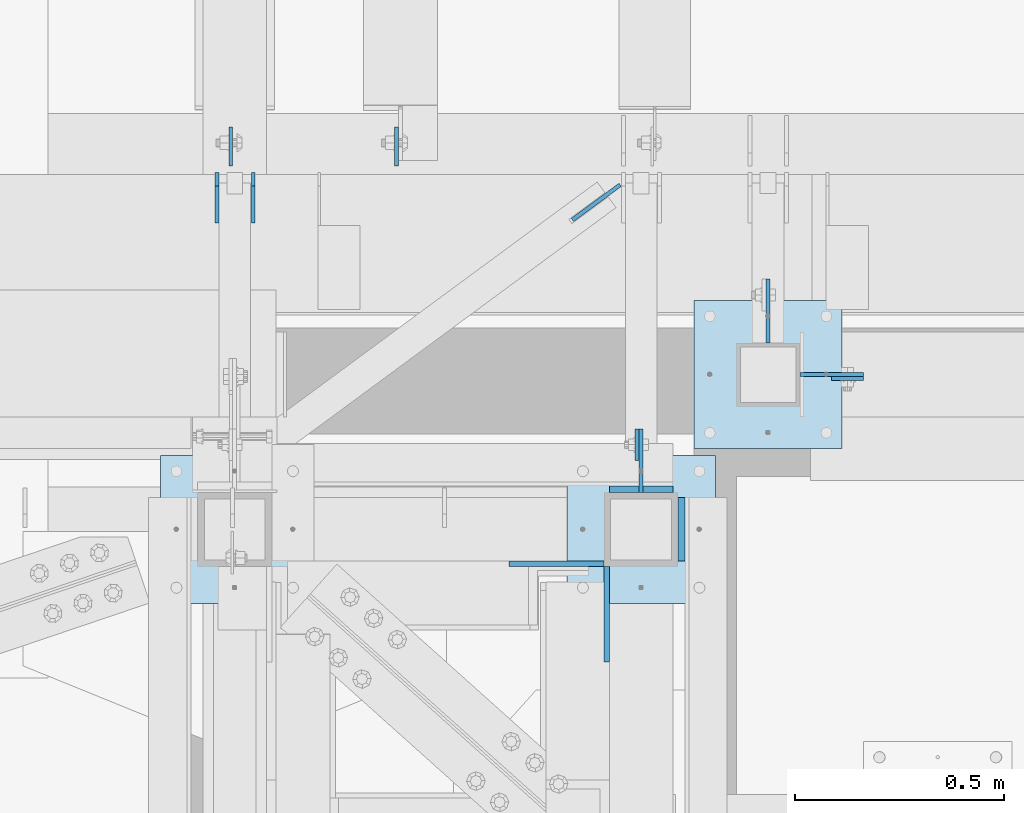
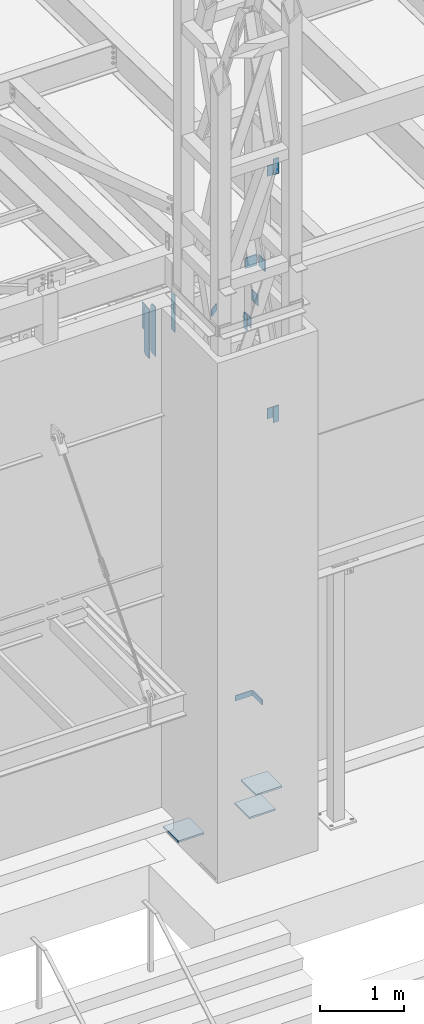
# One storey, part 1481 of 1763: 19 plates, 6 elements without a shape of their own.
"""IFC2X3 building model written with IfcOpenShell, lengths in millimetres."""

from ifc_helpers import new_model, si_unit, frame, origin_with_axes, place, context, subcontext, project, spatial, faceted_brep, material, type_object, element, aggregate, save


model = new_model("IFC2X3")

# Units and contexts
model_context = context("Model", 3, precision=1e-05, world=origin_with_axes())
body_context = subcontext(model_context, "Body", "Model", "MODEL_VIEW")
ifc_project = project(units=[si_unit("LENGTHUNIT", "METRE", prefix="MILLI"), si_unit("AREAUNIT", "SQUARE_METRE"), si_unit("VOLUMEUNIT", "CUBIC_METRE"), si_unit("MASSUNIT", "GRAM", prefix="KILO"), si_unit("TIMEUNIT", "SECOND"), si_unit("PLANEANGLEUNIT", "RADIAN"), si_unit("SOLIDANGLEUNIT", "STERADIAN"), si_unit("THERMODYNAMICTEMPERATUREUNIT", "DEGREE_CELSIUS"), si_unit("LUMINOUSINTENSITYUNIT", "LUMEN")], contexts=[model_context])

# Site, building, storey
site_placement = place(None, origin_with_axes())
site = spatial("IfcSite", under=ifc_project, at=site_placement, CompositionType="ELEMENT")
building_placement = place(site_placement, origin_with_axes())
building = spatial("IfcBuilding", under=site, at=building_placement, Name="Undefined", CompositionType="ELEMENT")
storey_placement = place(building_placement, origin_with_axes())
storey = spatial("IfcBuildingStorey", under=building, at=storey_placement, Name="Undefined", CompositionType="ELEMENT", Elevation=0.0)

# Assembly, plates
assembly_1_placement = place(storey_placement, origin_with_axes())
assembly_1 = element("IfcElementAssembly", 1, at=assembly_1_placement, inside=storey, Name="FRAME", AssemblyPlace="NOTDEFINED", PredefinedType="RIGID_FRAME")
ifc_material = material(Name="STEEL/A36")
plate_type_1 = type_object("IfcPlateType", PredefinedType="NOTDEFINED")
plate_1_placement = place(assembly_1_placement, frame((-47078.327008358, -14662.1506485031, 6845.29999694824), z_axis=(0.99999999999718, 2.37500000002911e-06, 0.0), x_axis=(0.0, 0.0, -1.0)))
plate_1 = element("IfcPlate", 2, at=plate_1_placement, type_object=plate_type_1, material=ifc_material, Name="PLATE", context=body_context, shape_type="Brep", body=[
    faceted_brep([(0.0, -6.34999999999491, 1.45519152283669e-11), (0.0, -6.35000000001855, 228.600006104178), (0.0, 6.34999999996944, 228.600006104134), (0.0, 6.34999999999491, -2.91038304567337e-11), (76.1999969482422, -6.35000000001855, 228.600006104178), (76.1999969482422, 6.34999999996944, 228.600006104134), (76.1999969482422, -6.34999999999491, 1.45519152283669e-11), (76.1999969482422, 6.34999999999491, -2.91038304567337e-11)], [[[0, 1, 2, 3]], [[1, 4, 5, 2]], [[4, 6, 7, 5]], [[6, 0, 3, 7]], [[5, 7, 3, 2]], [[6, 4, 1, 0]]]),
])
plate_2_placement = place(assembly_1_placement, frame((-46843.3772043448, -14897.1022094127, 6845.29999694824), z_axis=(0.0, 1.0, 0.0), x_axis=(0.0, 0.0, -1.0)))
plate_2 = element("IfcPlate", 3, at=plate_2_placement, type_object=plate_type_1, material=ifc_material, Name="PLATE", context=body_context, shape_type="Brep", body=[
    faceted_brep([(0.0, -6.34999999999491, 1.45519152283669e-11), (0.0, -6.35000000001855, 228.600006104178), (0.0, 6.34999999996944, 228.600006104134), (0.0, 6.34999999999491, -2.91038304567337e-11), (76.1999969482422, -6.35000000001855, 228.600006104178), (76.1999969482422, 6.34999999996944, 228.600006104134), (76.1999969482422, -6.34999999999491, 1.45519152283669e-11), (76.1999969482422, 6.34999999999491, -2.91038304567337e-11)], [[[0, 1, 2, 3]], [[1, 4, 5, 2]], [[4, 6, 7, 5]], [[6, 0, 3, 7]], [[5, 7, 3, 2]], [[6, 4, 1, 0]]]),
])

# Assembly, plate
assembly_2_placement = place(storey_placement, origin_with_axes())
assembly_2 = element("IfcElementAssembly", 4, at=assembly_2_placement, inside=storey, Name="BEAM", AssemblyPlace="NOTDEFINED", PredefinedType="RIGID_FRAME")
plate_type_2 = type_object("IfcPlateType", PredefinedType="NOTDEFINED")
plate_3_placement = place(assembly_2_placement, frame((-46304.0555859377, -14217.6514913088, 14058.9), z_axis=(0.0, 0.0, -1.0), x_axis=(1.0, 0.0, 0.0)))
plate_3 = element("IfcPlate", 5, at=plate_3_placement, type_object=plate_type_2, material=ifc_material, Name="PLATE", context=body_context, shape_type="Brep", body=[
    faceted_brep([(0.0, -4.76249999999982, 0.0), (-2.83762346953154e-10, -4.7624999996915, 228.600006103516), (-2.83762346953154e-10, 4.76250000028813, 228.600006103517), (0.0, 4.76249999999982, 0.0), (76.1999969480166, -4.76249999961874, 228.600006103516), (76.1999969480166, 4.76250000036089, 228.600006103517), (76.1999969482931, -4.76249999991705, 0.0), (76.1999969482931, 4.76250000006257, 1.81898940354586e-12)], [[[0, 1, 2, 3]], [[1, 4, 5, 2]], [[4, 6, 7, 5]], [[6, 0, 3, 7]], [[5, 7, 3, 2]], [[6, 4, 1, 0]]]),
])
aggregate(assembly_2, [plate_3])

assembly_3_placement = place(storey_placement, origin_with_axes())
assembly_3 = element("IfcElementAssembly", 6, at=assembly_3_placement, inside=storey, Name="BEAM", AssemblyPlace="NOTDEFINED", PredefinedType="RIGID_FRAME")
plate_4_placement = place(assembly_3_placement, frame((-46304.0555859377, -14217.6514913088, 10248.9), z_axis=(0.0, 0.0, 1.0), x_axis=(1.0, 0.0, 0.0)))
plate_4 = element("IfcPlate", 7, at=plate_4_placement, type_object=plate_type_2, material=ifc_material, Name="PLATE", context=body_context, shape_type="Brep", body=[
    faceted_brep([(0.0, -4.76249999999982, 0.0), (-2.83762346953154e-10, -4.7624999996915, 228.600006103516), (-2.83762346953154e-10, 4.76250000028813, 228.600006103517), (0.0, 4.76249999999982, 0.0), (76.1999969480166, -4.76249999961874, 228.600006103516), (76.1999969480166, 4.76250000036089, 228.600006103517), (76.1999969482931, -4.76249999991705, 0.0), (76.1999969482931, 4.76250000006257, 1.81898940354586e-12)], [[[0, 1, 2, 3]], [[1, 4, 5, 2]], [[4, 6, 7, 5]], [[6, 0, 3, 7]], [[5, 7, 3, 2]], [[6, 4, 1, 0]]]),
])
aggregate(assembly_3, [plate_4])

assembly_4_placement = place(storey_placement, origin_with_axes())
assembly_4 = element("IfcElementAssembly", 8, at=assembly_4_placement, inside=storey, Name="BEAM", AssemblyPlace="NOTDEFINED", PredefinedType="RIGID_FRAME")
plate_5_placement = place(assembly_4_placement, frame((-46770.3522072329, -14414.5021973104, 11858.625), z_axis=(0.0, 0.0, 1.0), x_axis=(0.0, 1.0, 0.0)))
plate_5 = element("IfcPlate", 9, at=plate_5_placement, type_object=plate_type_2, material=ifc_material, Name="PLATE", context=body_context, shape_type="Brep", body=[
    faceted_brep([(0.0, -4.76249999999982, 0.0), (-2.83762346953154e-10, -4.7624999996915, 228.600006103516), (-2.83762346953154e-10, 4.76250000028813, 228.600006103517), (0.0, 4.76249999999982, 0.0), (76.1999969480166, -4.76249999961874, 228.600006103516), (76.1999969480166, 4.76250000036089, 228.600006103517), (76.1999969482931, -4.76249999991705, 0.0), (76.1999969482931, 4.76250000006257, 1.81898940354586e-12)], [[[0, 1, 2, 3]], [[1, 4, 5, 2]], [[4, 6, 7, 5]], [[6, 0, 3, 7]], [[5, 7, 3, 2]], [[6, 4, 1, 0]]]),
])
aggregate(assembly_4, [plate_5])

# Assembly, plates
assembly_5_placement = place(storey_placement, origin_with_axes())
assembly_5 = element("IfcElementAssembly", 10, at=assembly_5_placement, inside=storey, Name="BEAM", AssemblyPlace="NOTDEFINED", PredefinedType="RIGID_FRAME")
plate_type_3 = type_object("IfcPlateType", PredefinedType="NOTDEFINED")
plate_6_placement = place(assembly_5_placement, frame((-47691.1023997267, -13844.5873186171, 11463.3375), z_axis=(0.0, 0.0, 1.0), x_axis=(0.0, 1.0, 0.0)))
plate_6 = element("IfcPlate", 11, at=plate_6_placement, type_object=plate_type_3, material=ifc_material, Name="PLATE", context=body_context, shape_type="Brep", body=[
    faceted_brep([(0.0, -4.76249999999982, 0.0), (0.0, -4.76249999999709, 714.375), (0.0, 4.76249999999709, 714.375), (0.0, 4.76249999999982, 0.0), (88.9000015258789, -4.76249999999709, 714.375), (88.9000015258789, 4.76249999999709, 714.375), (120.650001525879, -4.76249999999709, 682.625), (120.650001525879, 4.76249999999709, 682.625), (120.650001525879, -4.76249999999709, 31.75), (120.650001525879, 4.76249999999709, 31.75), (88.9000015258789, -4.76249999999709, 0.0), (88.9000015258789, 4.76249999999709, 0.0)], [[[0, 1, 2, 3]], [[1, 4, 5, 2]], [[4, 6, 7, 5]], [[6, 8, 9, 7]], [[8, 10, 11, 9]], [[10, 0, 3, 11]], [[5, 7, 9, 11, 3, 2]], [[10, 8, 6, 4, 1, 0]]]),
])
plate_7_placement = place(assembly_5_placement, frame((-47778.4148997267, -13844.5873186171, 11463.3375), z_axis=(0.0, 0.0, 1.0), x_axis=(0.0, 1.0, 0.0)))
plate_7 = element("IfcPlate", 12, at=plate_7_placement, type_object=plate_type_3, material=ifc_material, Name="PLATE", context=body_context, shape_type="Brep", body=[
    faceted_brep([(0.0, -4.76249999999982, 0.0), (0.0, -4.76249999999709, 714.375), (0.0, 4.76249999999709, 714.375), (0.0, 4.76249999999982, 0.0), (88.9000015258789, -4.76249999999709, 714.375), (88.9000015258789, 4.76249999999709, 714.375), (120.650001525879, -4.76249999999709, 682.625), (120.650001525879, 4.76249999999709, 682.625), (120.650001525879, -4.76249999999709, 31.75), (120.650001525879, 4.76249999999709, 31.75), (88.9000015258789, -4.76249999999709, 0.0), (88.9000015258789, 4.76249999999709, 0.0)], [[[0, 1, 2, 3]], [[1, 4, 5, 2]], [[4, 6, 7, 5]], [[6, 8, 9, 7]], [[8, 10, 11, 9]], [[10, 0, 3, 11]], [[5, 7, 9, 11, 3, 2]], [[10, 8, 6, 4, 1, 0]]]),
])

assembly_6_placement = place(storey_placement, origin_with_axes())
assembly_6 = element("IfcElementAssembly", 13, at=assembly_6_placement, inside=storey, Name="COLUMN", AssemblyPlace="NOTDEFINED", PredefinedType="RIGID_FRAME")
plate_type_4 = type_object("IfcPlateType", PredefinedType="NOTDEFINED")
plate_8_placement = place(assembly_6_placement, frame((-46227.855589037, -14208.126492046, 13830.2999938965), z_axis=(0.0, 0.0, 1.0), x_axis=(-1.0, 0.0, 0.0)))
plate_8 = element("IfcPlate", 14, at=plate_8_placement, type_object=plate_type_4, material=ifc_material, Name="PLATE", context=body_context, shape_type="Brep", body=[
    faceted_brep([(0.0, -4.76249999999982, 0.0), (-3.05175672110636e-06, -4.7625000002663, 152.399993896484), (-3.05175490211695e-06, 4.76249999972788, 152.399993896484), (0.0, 4.76249999999982, 0.0), (152.400009155272, -4.76249999975698, 152.399993896484), (152.400009155273, 4.76250000024447, 152.399993896484), (152.400009155272, -4.76249999948777, 5.45696821063757e-12), (152.400009155273, 4.76250000051368, 3.63797880709171e-12)], [[[0, 1, 2, 3]], [[1, 4, 5, 2]], [[4, 6, 7, 5]], [[6, 0, 3, 7]], [[5, 7, 3, 2]], [[6, 4, 1, 0]]]),
])
plate_9_placement = place(assembly_6_placement, frame((-46456.455405856, -13979.5264678355, 12087.2250061035), z_axis=(0.0, 0.0, -1.0), x_axis=(0.0, -1.0, 0.0)))
plate_9 = element("IfcPlate", 15, at=plate_9_placement, type_object=plate_type_4, material=ifc_material, Name="PLATE", context=body_context, shape_type="Brep", body=[
    faceted_brep([(0.0, -4.76249999999982, 0.0), (-3.05175672110636e-06, -4.7625000002663, 152.399993896484), (-3.05175490211695e-06, 4.76249999972788, 152.399993896484), (0.0, 4.76249999999982, 0.0), (152.400009155272, -4.76249999975698, 152.399993896484), (152.400009155273, 4.76250000024447, 152.399993896484), (152.400009155272, -4.76249999948777, 5.45696821063757e-12), (152.400009155273, 4.76250000051368, 3.63797880709171e-12)], [[[0, 1, 2, 3]], [[1, 4, 5, 2]], [[4, 6, 7, 5]], [[6, 0, 3, 7]], [[5, 7, 3, 2]], [[6, 4, 1, 0]]]),
])
plate_10_placement = place(assembly_6_placement, frame((-46227.855589037, -14208.126492046, 10477.5000061035), z_axis=(0.0, 0.0, -1.0), x_axis=(-1.0, 0.0, 0.0)))
plate_10 = element("IfcPlate", 16, at=plate_10_placement, type_object=plate_type_4, material=ifc_material, Name="PLATE", context=body_context, shape_type="Brep", body=[
    faceted_brep([(0.0, -4.76249999999982, 0.0), (-3.05175672110636e-06, -4.7625000002663, 152.399993896484), (-3.05175490211695e-06, 4.76249999972788, 152.399993896484), (0.0, 4.76249999999982, 0.0), (152.400009155272, -4.76249999975698, 152.399993896484), (152.400009155273, 4.76250000024447, 152.399993896484), (152.400009155272, -4.76249999948777, 5.45696821063757e-12), (152.400009155273, 4.76250000051368, 3.63797880709171e-12)], [[[0, 1, 2, 3]], [[1, 4, 5, 2]], [[4, 6, 7, 5]], [[6, 0, 3, 7]], [[5, 7, 3, 2]], [[6, 4, 1, 0]]]),
])

# Plate
plate_11_placement = place(assembly_1_placement, frame((-46760.8272076138, -14338.3022002574, 12087.2250061035), z_axis=(0.0, 0.0, -1.0), x_axis=(0.0, -1.0, 0.0)))
plate_11 = element("IfcPlate", 17, at=plate_11_placement, type_object=plate_type_4, material=ifc_material, Name="PLATE", context=body_context, shape_type="Brep", body=[
    faceted_brep([(0.0, -4.76249999999982, 0.0), (-3.05175672110636e-06, -4.7625000002663, 152.399993896484), (-3.05175490211695e-06, 4.76249999972788, 152.399993896484), (0.0, 4.76249999999982, 0.0), (152.400009155272, -4.76249999975698, 152.399993896484), (152.400009155273, 4.76250000024447, 152.399993896484), (152.400009155272, -4.76249999948777, 5.45696821063757e-12), (152.400009155273, 4.76250000051368, 3.63797880709171e-12)], [[[0, 1, 2, 3]], [[1, 4, 5, 2]], [[4, 6, 7, 5]], [[6, 0, 3, 7]], [[5, 7, 3, 2]], [[6, 4, 1, 0]]]),
])

plate_type_5 = type_object("IfcPlateType", PredefinedType="NOTDEFINED")
plate_12_placement = place(assembly_6_placement, frame((-46634.2555979689, -14030.3264769908, 5080.0), z_axis=(1.0, 0.0, 0.0), x_axis=(0.0, -1.0, 0.0)))
plate_12 = element("IfcPlate", 18, at=plate_12_placement, type_object=plate_type_5, material=ifc_material, Name="PLATE", context=body_context, shape_type="Brep", body=[
    faceted_brep([(0.0, -12.6999999999971, -1.81898940354586e-12), (0.0, -12.6999999999998, 355.600006103516), (0.0, 12.6999999999998, 355.600006103516), (0.0, 12.6999999999971, -1.81898940354586e-12), (355.600006103516, -12.6999999999998, 355.600006103516), (355.600006103516, 12.6999999999998, 355.600006103516), (355.600006103516, -12.6999999999998, 0.0), (355.600006103516, 12.6999999999998, 0.0)], [[[0, 1, 2, 3]], [[1, 4, 5, 2]], [[4, 6, 7, 5]], [[6, 0, 3, 7]], [[5, 7, 3, 2]], [[6, 4, 1, 0]]]),
])

aggregate(assembly_6, [plate_12, plate_8, plate_9, plate_10])

plate_13_placement = place(assembly_1_placement, frame((-46938.6272044142, -14401.8022094127, 5079.99999999999), z_axis=(1.0, 0.0, 0.0), x_axis=(0.0, -1.0, 0.0)))
plate_13 = element("IfcPlate", 19, at=plate_13_placement, type_object=plate_type_5, material=ifc_material, Name="PLATE", context=body_context, shape_type="Brep", body=[
    faceted_brep([(0.0, -12.6999999999971, -1.81898940354586e-12), (0.0, -12.6999999999998, 355.600006103516), (0.0, 12.6999999999998, 355.600006103516), (0.0, 12.6999999999971, -1.81898940354586e-12), (355.600006103516, -12.6999999999998, 355.600006103516), (355.600006103516, 12.6999999999998, 355.600006103516), (355.600006103516, -12.6999999999998, 0.0), (355.600006103516, 12.6999999999998, 0.0)], [[[0, 1, 2, 3]], [[1, 4, 5, 2]], [[4, 6, 7, 5]], [[6, 0, 3, 7]], [[5, 7, 3, 2]], [[6, 4, 1, 0]]]),
])

plate_14_placement = place(assembly_1_placement, frame((-47913.3523997267, -14401.8022094127, 5080.0), z_axis=(1.0, 0.0, 0.0), x_axis=(0.0, -1.0, 0.0)))
plate_14 = element("IfcPlate", 20, at=plate_14_placement, type_object=plate_type_5, material=ifc_material, Name="PLATE", context=body_context, shape_type="Brep", body=[
    faceted_brep([(0.0, -12.6999999999971, -1.81898940354586e-12), (0.0, -12.6999999999998, 355.600006103516), (0.0, 12.6999999999998, 355.600006103516), (0.0, 12.6999999999971, -1.81898940354586e-12), (355.600006103516, -12.6999999999998, 355.600006103516), (355.600006103516, 12.6999999999998, 355.600006103516), (355.600006103516, -12.6999999999998, 0.0), (355.600006103516, 12.6999999999998, 0.0)], [[[0, 1, 2, 3]], [[1, 4, 5, 2]], [[4, 6, 7, 5]], [[6, 0, 3, 7]], [[5, 7, 3, 2]], [[6, 4, 1, 0]]]),
])

plate_type_6 = type_object("IfcPlateType", PredefinedType="NOTDEFINED")
plate_15_placement = place(assembly_5_placement, frame((-46925.584294499, -13837.2551280174, 11769.725), z_axis=(0.0, 0.0, 1.0), x_axis=(0.805393904162817, 0.592739959119828, 0.0)))
plate_15 = element("IfcPlate", 21, at=plate_15_placement, type_object=plate_type_6, material=ifc_material, Name="PLATE", context=body_context, shape_type="Brep", body=[
    faceted_brep([(0.0, -4.76249999999982, 0.0), (1.45519152283669e-11, -4.76250000000448, 101.60001373291), (0.0, 4.76250000000243, 101.60001373291), (0.0, 4.76249999999982, 0.0), (141.929504394669, -4.76250000004438, 101.600006103516), (141.929504394677, 4.76249999992797, 101.600006103516), (141.929504394669, -4.76250000004438, 0.0), (141.929504394677, 4.76249999992797, 0.0)], [[[0, 1, 2, 3]], [[1, 4, 5, 2]], [[4, 6, 7, 5]], [[6, 0, 3, 7]], [[5, 7, 3, 2]], [[6, 4, 1, 0]]]),
])

plate_type_7 = type_object("IfcPlateType", PredefinedType="NOTDEFINED")
plate_16_placement = place(assembly_1_placement, frame((-46684.6272044142, -14482.7647094127, 12979.3999999999), z_axis=(0.0, 0.0, -1.0), x_axis=(-1.0, 0.0, 0.0)))
plate_16 = element("IfcPlate", 22, at=plate_16_placement, type_object=plate_type_7, material=ifc_material, Name="PLATE", context=body_context, shape_type="Brep", body=[
    faceted_brep([(-7.27595761418343e-12, -7.9375, 0.0), (7.27595761418343e-12, -7.9375, 152.399993896484), (7.27595761418343e-12, 7.9375, 152.399993896484), (-7.27595761418343e-12, 7.9375, 0.0), (152.399993896484, -7.9375, 152.399993896484), (152.399993896484, 7.9375, 152.399993896484), (152.399993896484, -7.9375, -1.81898940354586e-12), (152.399993896484, 7.9375, -1.81898940354586e-12)], [[[0, 1, 2, 3]], [[1, 4, 5, 2]], [[4, 6, 7, 5]], [[6, 0, 3, 7]], [[5, 7, 3, 2]], [[6, 4, 1, 0]]]),
])

plate_17_placement = place(assembly_1_placement, frame((-46663.9897044142, -14655.8022094127, 12979.4), z_axis=(0.0, 0.0, -1.0), x_axis=(0.0, 1.0, 0.0)))
plate_17 = element("IfcPlate", 23, at=plate_17_placement, type_object=plate_type_7, material=ifc_material, Name="PLATE", context=body_context, shape_type="Brep", body=[
    faceted_brep([(-7.27595761418343e-12, -7.9375, 0.0), (7.27595761418343e-12, -7.9375, 152.399993896484), (7.27595761418343e-12, 7.9375, 152.399993896484), (-7.27595761418343e-12, 7.9375, 0.0), (152.399993896484, -7.9375, 152.399993896484), (152.399993896484, 7.9375, 152.399993896484), (152.399993896484, -7.9375, -1.81898940354586e-12), (152.399993896484, 7.9375, -1.81898940354586e-12)], [[[0, 1, 2, 3]], [[1, 4, 5, 2]], [[4, 6, 7, 5]], [[6, 0, 3, 7]], [[5, 7, 3, 2]], [[6, 4, 1, 0]]]),
])

aggregate(assembly_1, [plate_1, plate_2, plate_16, plate_17, plate_11, plate_13, plate_14])

plate_type_8 = type_object("IfcPlateType", PredefinedType="NOTDEFINED")
plate_18_placement = place(assembly_5_placement, frame((-47745.0887459181, -13708.0623186171, 12141.4381106629), z_axis=(0.0, 1.0, 0.0), x_axis=(0.0, 0.0, -1.0)))
plate_18 = element("IfcPlate", 24, at=plate_18_placement, type_object=plate_type_8, material=ifc_material, Name="PLATE", context=body_context, shape_type="Brep", body=[
    faceted_brep([(0.0, -3.96900000000096, 0.0), (0.0, -3.96899999999732, 93.6624984741211), (0.0, 3.96899999999732, 93.6624984741211), (0.0, 3.96900000000096, 0.0), (381.0, -3.96899999999732, 93.6624984741211), (381.0, 3.96899999999732, 93.6624984741211), (381.0, -3.96900000001915, 3.34694050252438e-10), (381.0, 3.9690000000046, 3.20142135024071e-10)], [[[0, 1, 2, 3]], [[1, 4, 5, 2]], [[4, 6, 7, 5]], [[6, 0, 3, 7]], [[5, 7, 3, 2]], [[6, 4, 1, 0]]]),
])

plate_type_9 = type_object("IfcPlateType", PredefinedType="NOTDEFINED")
plate_19_placement = place(assembly_5_placement, frame((-47347.3051308412, -13708.0623186171, 12141.4381181097), z_axis=(0.0, 1.0, 0.0), x_axis=(0.0, 0.0, -1.0)))
plate_19 = element("IfcPlate", 25, at=plate_19_placement, type_object=plate_type_9, material=ifc_material, Name="PLATE", context=body_context, shape_type="Brep", body=[
    faceted_brep([(0.0, -4.76249999999982, 0.0), (0.0, -4.76249999999709, 93.6624984741211), (0.0, 4.76249999999709, 93.6624984741211), (0.0, 4.76249999999982, 0.0), (533.400024414062, -4.76249999999709, 93.6624984741211), (533.400024414062, 4.76249999999709, 93.6624984741211), (533.400024414062, -4.76250000000073, 0.0), (533.400024414062, 4.76250000000073, 0.0)], [[[0, 1, 2, 3]], [[1, 4, 5, 2]], [[4, 6, 7, 5]], [[6, 0, 3, 7]], [[5, 7, 3, 2]], [[6, 4, 1, 0]]]),
])

aggregate(assembly_5, [plate_15, plate_6, plate_7, plate_19, plate_18])

save(model, "model.ifc")
